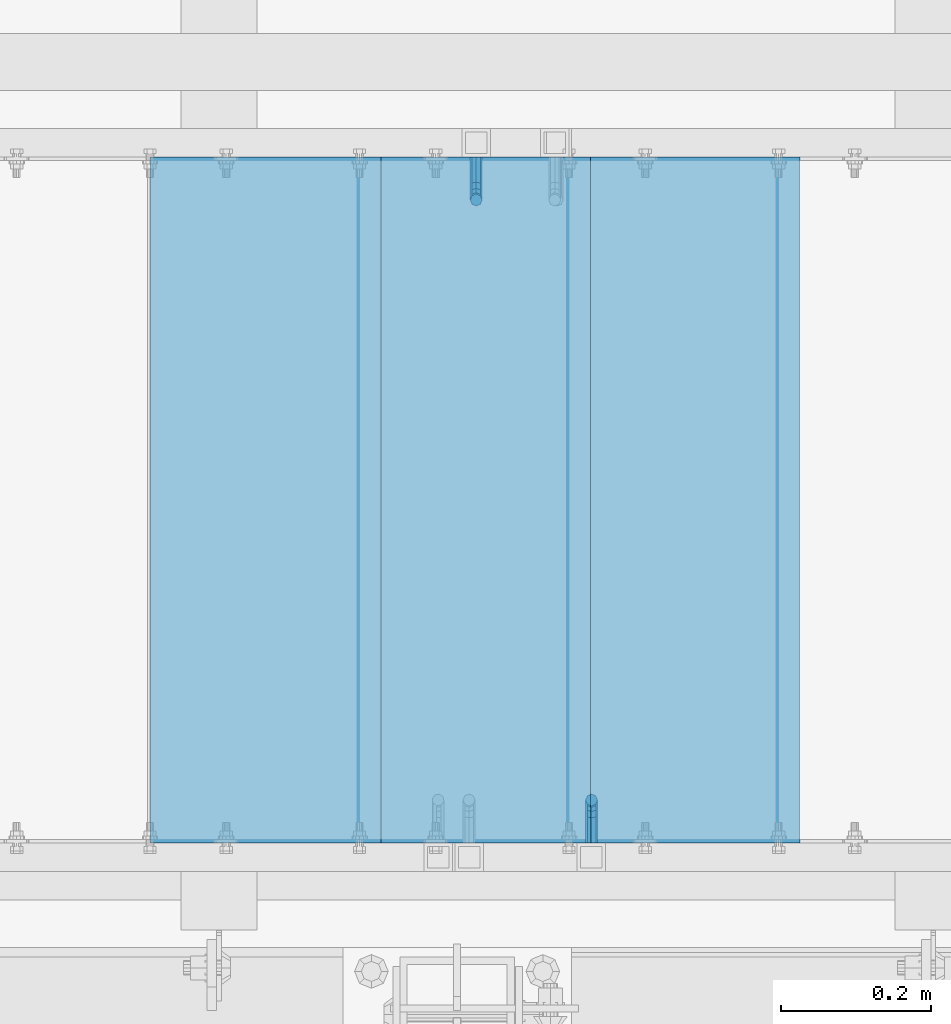
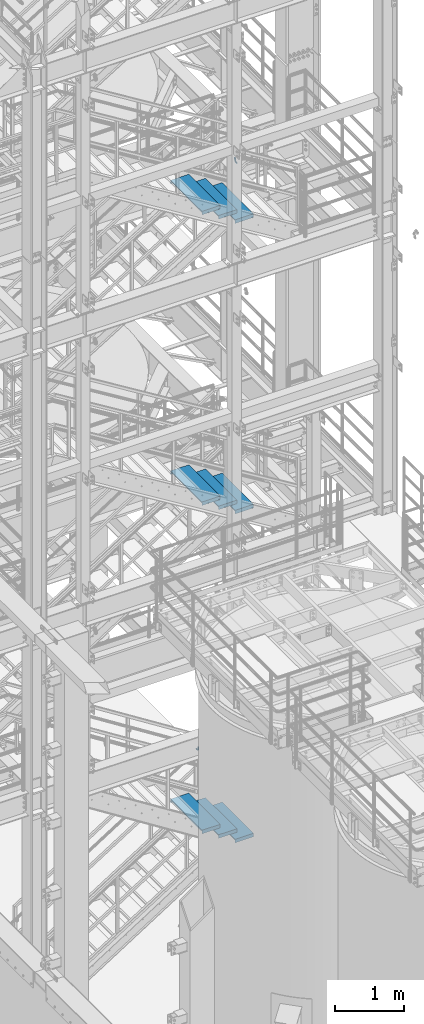
# One storey, part 1149 of 1876: 11 beams, 5 elements without a shape of their own.
"""IFC2X3 building model written with IfcOpenShell, lengths in millimetres."""

from ifc_helpers import new_model, si_unit, frame, origin_with_axes, place, context, subcontext, project, spatial, faceted_brep, material, type_object, element, aggregate, save


model = new_model("IFC2X3")

# Units and contexts
model_context = context("Model", 3, precision=1e-05, world=origin_with_axes())
body_context = subcontext(model_context, "Body", "Model", "MODEL_VIEW")
ifc_project = project(units=[si_unit("LENGTHUNIT", "METRE", prefix="MILLI"), si_unit("AREAUNIT", "SQUARE_METRE"), si_unit("VOLUMEUNIT", "CUBIC_METRE"), si_unit("MASSUNIT", "GRAM", prefix="KILO"), si_unit("TIMEUNIT", "SECOND"), si_unit("PLANEANGLEUNIT", "RADIAN"), si_unit("SOLIDANGLEUNIT", "STERADIAN"), si_unit("THERMODYNAMICTEMPERATUREUNIT", "DEGREE_CELSIUS"), si_unit("LUMINOUSINTENSITYUNIT", "LUMEN")], contexts=[model_context])

# Site, building, storey
site_placement = place(None, origin_with_axes())
site = spatial("IfcSite", under=ifc_project, at=site_placement, CompositionType="ELEMENT")
building_placement = place(site_placement, origin_with_axes())
building = spatial("IfcBuilding", under=site, at=building_placement, Name="Undefined", CompositionType="ELEMENT")
storey_placement = place(building_placement, origin_with_axes())
storey = spatial("IfcBuildingStorey", under=building, at=storey_placement, Name="Undefined", CompositionType="ELEMENT", Elevation=0.0)

# Assembly, beam
assembly_1_placement = place(storey_placement, origin_with_axes())
assembly_1 = element("IfcElementAssembly", 1, at=assembly_1_placement, inside=storey, Name="RAIL", AssemblyPlace="NOTDEFINED", PredefinedType="RIGID_FRAME")
ifc_material = material(Name="STEEL/A36")
beam_type_1 = type_object("IfcBeamType", PredefinedType="NOTDEFINED")
beam_1_placement = place(assembly_1_placement, frame((5259.26600612836, -6883.39999885446, 14836.1019596161), z_axis=(-1.0, 0.0, 0.0), x_axis=(0.0, 1.0, 0.0)))
beam_1 = element("IfcBeam", 2, at=beam_1_placement, type_object=beam_type_1, material=ifc_material, Name="BRACKET", context=body_context, shape_type="Brep", body=[
    faceted_brep([(0.0, -5.61266007566822, 5.61266007566883), (0.0, 0.0, 7.9375), (0.0, 5.61266007566822, 5.61266007566883), (0.0, 7.9375, 0.0), (0.0, 5.61266007566822, -5.61266007566883), (0.0, 0.0, -7.9375), (0.0, -5.61266007566822, -5.61266007566883), (0.0, -7.9375, 0.0), (23.8125, 5.61266007566883, 5.61266007566792), (23.8125, 7.9375, 0.0), (23.8125, 5.61266007566883, -5.61266007566792), (23.8125, 0.0, -7.9375), (23.8125, -5.61266007566883, -5.61266007566792), (23.8125, -7.9375, 0.0), (23.8125, -5.61266007566883, 5.61266007566792), (23.8125, 0.0, 7.9375), (36.5702095103989, -2.53766620105534, 7.9375), (38.7180815328547, 2.64775556579752, 5.61266007566792), (39.6077592547972, 4.79562758825296, 0.0), (38.7180815328547, 2.64775556579752, -5.61266007566792), (36.5702095103989, -2.53766620105534, -7.9375), (34.4223374879439, -7.72308796790867, -5.61266007566792), (33.5326597660014, -9.87095999036364, 0.0), (34.4223374879439, -7.72308796790867, 5.61266007566792), (43.4169233967659, -13.733078129113, 5.61266007566792), (47.385673396765, -9.76432812911298, 7.9375), (41.7730133210971, -15.3769882047809, 0.0), (43.4169233967659, -13.733078129113, -5.61266007566792), (47.385673396765, -9.76432812911298, -7.9375), (51.354423396765, -5.79557812911253, -5.61266007566792), (52.9983334724338, -4.15166805344461, 0.0), (51.354423396765, -5.79557812911253, 5.61266007566792), (54.6123353248231, -20.5797920154787, 7.9375), (59.7977570916764, -18.4319199930233, 5.61266007566792), (49.4269135579698, -22.7276640379341, 5.61266007566792), (47.2790415355148, -23.6173417598766, 0.0), (49.4269135579698, -22.7276640379341, -5.61266007566792), (54.6123353248231, -20.5797920154787, -7.9375), (59.7977570916764, -18.4319199930233, -5.61266007566792), (61.9456291141314, -17.5422422710808, 0.0), (62.7626616015468, -33.3375015258789, 5.61266007566792), (65.0875015258789, -33.3375015258789, 0.0), (57.1500015258789, -33.3375015258789, 7.9375), (51.5373414502101, -33.3375015258789, 5.61266007566792), (49.2125015258789, -33.3375015258789, 0.0), (51.5373414502101, -33.3375015258789, -5.61266007566792), (57.1500015258789, -33.3375015258789, -7.9375), (62.7626616015468, -33.3375015258789, -5.61266007566792), (65.0875015258789, -66.4903966648035, 0.0), (62.7626616015468, -63.0131930011103, -5.61266007566792), (57.1500015258789, -61.5728880844745, -7.9375), (51.537341450211, -63.0131930011103, -5.61266007566792), (49.2125015258789, -66.4903966648035, 0.0), (51.537341450211, -69.9676003284985, 5.61266007566792), (57.1500015258789, -71.4079052451343, 7.9375), (62.7626616015468, -69.9676003284985, 5.61266007566792)], [[[0, 1, 2, 3, 4, 5, 6, 7]], [[3, 2, 8, 9]], [[4, 3, 9, 10]], [[5, 4, 10, 11]], [[6, 5, 11, 12]], [[7, 6, 12, 13]], [[0, 7, 13, 14]], [[1, 0, 14, 15]], [[2, 1, 15, 8]], [[8, 15, 16, 17]], [[9, 8, 17, 18]], [[10, 9, 18, 19]], [[11, 10, 19, 20]], [[12, 11, 20, 21]], [[13, 12, 21, 22]], [[14, 13, 22, 23]], [[15, 14, 23, 16]], [[23, 24, 25, 16]], [[22, 26, 24, 23]], [[21, 27, 26, 22]], [[20, 28, 27, 21]], [[19, 29, 28, 20]], [[18, 30, 29, 19]], [[17, 31, 30, 18]], [[16, 25, 31, 17]], [[25, 32, 33, 31]], [[24, 34, 32, 25]], [[26, 35, 34, 24]], [[27, 36, 35, 26]], [[28, 37, 36, 27]], [[29, 38, 37, 28]], [[30, 39, 38, 29]], [[31, 33, 39, 30]], [[33, 40, 41, 39]], [[32, 42, 40, 33]], [[34, 43, 42, 32]], [[35, 44, 43, 34]], [[36, 45, 44, 35]], [[37, 46, 45, 36]], [[38, 47, 46, 37]], [[39, 41, 47, 38]], [[47, 41, 48, 49]], [[46, 47, 49, 50]], [[45, 46, 50, 51]], [[44, 45, 51, 52]], [[43, 44, 52, 53]], [[42, 43, 53, 54]], [[40, 42, 54, 55]], [[41, 40, 55, 48]], [[54, 53, 52, 51, 50, 49, 48, 55]]]),
])
aggregate(assembly_1, [beam_1])

assembly_2_placement = place(storey_placement, origin_with_axes())
assembly_2 = element("IfcElementAssembly", 3, at=assembly_2_placement, inside=storey, Name="RAIL", AssemblyPlace="NOTDEFINED", PredefinedType="RIGID_FRAME")
beam_2_placement = place(assembly_2_placement, frame((5105.40000153775, -5969.00000106773, 3934.46117682293), z_axis=(-1.0, 0.0, 0.0), x_axis=(0.0, -1.0, 0.0)))
beam_2 = element("IfcBeam", 4, at=beam_2_placement, type_object=beam_type_1, material=ifc_material, Name="BRACKET", context=body_context, shape_type="Brep", body=[
    faceted_brep([(0.0, -5.61266007566822, 5.61266007566883), (0.0, 0.0, 7.9375), (0.0, 5.61266007566822, 5.61266007566883), (0.0, 7.9375, 0.0), (0.0, 5.61266007566822, -5.61266007566883), (0.0, 0.0, -7.9375), (0.0, -5.61266007566822, -5.61266007566883), (0.0, -7.9375, 0.0), (23.8125, -5.61266007566883, -5.61266007566792), (23.8125, -7.9375, 0.0), (23.8125, -5.61266007566883, 5.61266007566792), (23.8125, 0.0, 7.9375), (23.8125, 5.61266007566883, 5.61266007566792), (23.8125, 7.9375, 0.0), (23.8125, 5.61266007566883, -5.61266007566792), (23.8125, 0.0, -7.9375), (36.5702095103998, 2.53766620105671, -7.9375), (38.7180815328556, -2.64775556579843, -5.61266007566792), (39.6077592547981, -4.79562758825341, 0.0), (38.7180815328556, -2.64775556579843, 5.61266007566792), (36.5702095103998, 2.53766620105671, 7.9375), (34.4223374879448, 7.72308796790821, 5.61266007566792), (33.5326597660023, 9.87095999036319, 0.0), (34.4223374879448, 7.72308796790821, -5.61266007566792), (43.4169233967659, 13.733078129113, -5.61266007566792), (47.3856733967659, 9.76432812911298, -7.9375), (41.773013321098, 15.3769882047818, 0.0), (43.4169233967659, 13.733078129113, 5.61266007566792), (47.3856733967659, 9.76432812911298, 7.9375), (51.3544233967659, 5.79557812911298, 5.61266007566792), (52.9983334724348, 4.15166805344415, 0.0), (51.3544233967659, 5.79557812911298, -5.61266007566792), (54.6123353248231, 20.5797920154801, -7.9375), (59.7977570916764, 18.4319199930251, -5.61266007566792), (49.4269135579698, 22.727664037935, -5.61266007566792), (47.2790415355148, 23.6173417598766, 0.0), (49.4269135579698, 22.727664037935, 5.61266007566792), (54.6123353248231, 20.5797920154801, 7.9375), (59.7977570916764, 18.4319199930251, 5.61266007566792), (61.9456291141314, 17.5422422710835, 0.0), (62.7626616015468, 33.3375015258789, -5.61266007566792), (65.0875015258789, 33.3375015258789, 0.0), (57.1500015258789, 33.3375015258789, -7.9375), (51.5373414502101, 33.3375015258789, -5.61266007566792), (49.2125015258789, 33.3375015258789, 0.0), (51.5373414502101, 33.3375015258789, 5.61266007566792), (57.1500015258789, 33.3375015258789, 7.9375), (62.7626616015468, 33.3375015258789, 5.61266007566792), (65.0875015258789, 67.3558732176816, 0.0), (62.7626616015468, 70.9165696288755, 5.61266007566837), (57.1500015258789, 72.3914583738861, 7.9375), (51.537341450211, 70.9165696288755, 5.61266007566837), (49.2125015258789, 67.3558732176816, 0.0), (51.537341450211, 63.7951768064877, -5.61266007566837), (57.1500015258789, 62.3202880614781, -7.9375), (62.7626616015468, 63.7951768064877, -5.61266007566837)], [[[0, 1, 2, 3, 4, 5, 6, 7]], [[7, 6, 8, 9]], [[0, 7, 9, 10]], [[1, 0, 10, 11]], [[2, 1, 11, 12]], [[3, 2, 12, 13]], [[4, 3, 13, 14]], [[5, 4, 14, 15]], [[6, 5, 15, 8]], [[8, 15, 16, 17]], [[9, 8, 17, 18]], [[10, 9, 18, 19]], [[11, 10, 19, 20]], [[12, 11, 20, 21]], [[13, 12, 21, 22]], [[14, 13, 22, 23]], [[15, 14, 23, 16]], [[23, 24, 25, 16]], [[22, 26, 24, 23]], [[21, 27, 26, 22]], [[20, 28, 27, 21]], [[19, 29, 28, 20]], [[18, 30, 29, 19]], [[17, 31, 30, 18]], [[16, 25, 31, 17]], [[25, 32, 33, 31]], [[24, 34, 32, 25]], [[26, 35, 34, 24]], [[27, 36, 35, 26]], [[28, 37, 36, 27]], [[29, 38, 37, 28]], [[30, 39, 38, 29]], [[31, 33, 39, 30]], [[33, 40, 41, 39]], [[32, 42, 40, 33]], [[34, 43, 42, 32]], [[35, 44, 43, 34]], [[36, 45, 44, 35]], [[37, 46, 45, 36]], [[38, 47, 46, 37]], [[39, 41, 47, 38]], [[47, 41, 48, 49]], [[46, 47, 49, 50]], [[45, 46, 50, 51]], [[44, 45, 51, 52]], [[43, 44, 52, 53]], [[42, 43, 53, 54]], [[40, 42, 54, 55]], [[41, 40, 55, 48]], [[54, 53, 52, 51, 50, 49, 48, 55]]]),
])
aggregate(assembly_2, [beam_2])

# Assembly, beams
assembly_3_placement = place(storey_placement, origin_with_axes())
assembly_3 = element("IfcElementAssembly", 5, at=assembly_3_placement, inside=storey, Name="STRINGER", AssemblyPlace="NOTDEFINED", PredefinedType="RIGID_FRAME")
beam_type_2 = type_object("IfcBeamType", PredefinedType="NOTDEFINED")
beam_3_placement = place(assembly_3_placement, frame((4824.41250077649, -5973.76300114651, 14175.0814814819), z_axis=(1.0, 0.0, 0.0), x_axis=(0.0, -1.0, 0.0)))
beam_3 = element("IfcBeam", 6, at=beam_3_placement, type_object=beam_type_2, material=ifc_material, Name="TREAD", context=body_context, shape_type="Brep", body=[
    faceted_brep([(-7.45785655453801e-11, 53.9750000000167, -153.9875), (-7.45785655453801e-11, 53.9750000000167, 153.987506103515), (0.0, 9.52499999999964, 153.9875), (-7.45785655453801e-11, 9.52499999999964, -153.9875), (-4.76300000007541, 53.9750000000167, -153.9875), (-4.76300000007541, 53.9750000000167, 153.987506103515), (-4.76300000007541, -9.52499999998327, -153.9875), (-4.76300000007541, -9.52500000019427, 153.987536621094), (909.637000008669, -9.52500000248983, 153.987506103515), (909.637000008669, 53.9749999975102, 153.987506103515), (904.87400000867, 53.9749999975102, 153.987506103515), (904.87400000867, 9.52499999999964, 153.987506103515), (-7.45785655453801e-11, -9.52500000019427, 153.987536621094), (904.87400000867, -9.52500000248983, 153.987506103515), (904.87400000867, 9.52499999999964, -153.9875), (909.637000008669, -9.52500000248983, -153.9875), (909.637000008669, 53.9749999975102, -153.9875), (904.87400000867, 53.9749999975102, -153.9875)], [[[0, 1, 2, 3]], [[1, 0, 4, 5]], [[5, 4, 6, 7]], [[8, 9, 10, 11, 2, 1, 5, 7, 12, 13]], [[14, 3, 2, 11]], [[15, 8, 13, 12, 7, 6]], [[9, 16, 17, 10]], [[16, 9, 8, 15]], [[16, 15, 6, 4, 0, 3, 14, 17]], [[10, 17, 14, 11]]]),
])
beam_4_placement = place(assembly_3_placement, frame((5103.81250069809, -5973.76300114632, 14001.9851851856), z_axis=(1.0, 0.0, 0.0), x_axis=(0.0, -1.0, 0.0)))
beam_4 = element("IfcBeam", 7, at=beam_4_placement, type_object=beam_type_2, material=ifc_material, Name="TREAD", context=body_context, shape_type="Brep", body=[
    faceted_brep([(-7.45785655453801e-11, 53.9750000000167, -153.9875), (-7.45785655453801e-11, 53.9750000000167, 153.987506103515), (0.0, 9.52499999999964, 153.9875), (-7.45785655453801e-11, 9.52499999999964, -153.9875), (-4.76300000007541, 53.9750000000167, -153.9875), (-4.76300000007541, 53.9750000000167, 153.987506103515), (-4.76300000007541, -9.52499999998327, -153.9875), (-4.76300000007541, -9.52500000019427, 153.987536621094), (909.637000008669, 53.9749999975102, 153.987506103515), (904.87400000867, 53.9749999975102, 153.987506103515), (904.87400000867, 9.52499999999964, 153.987506103515), (909.637000008669, -9.52500000248983, 153.987506103515), (904.87400000867, 9.52499999999964, -153.9875), (909.637000008669, -9.52500000248983, -153.9875), (909.637000008669, 53.9749999975102, -153.9875), (904.87400000867, 53.9749999975102, -153.9875)], [[[0, 1, 2, 3]], [[1, 0, 4, 5]], [[5, 4, 6, 7]], [[8, 9, 10, 2, 1, 5, 7, 11]], [[12, 3, 2, 10]], [[13, 11, 7, 6]], [[8, 14, 15, 9]], [[14, 8, 11, 13]], [[14, 13, 6, 4, 0, 3, 12, 15]], [[9, 15, 12, 10]]]),
])
beam_5_placement = place(assembly_3_placement, frame((5383.21250061969, -5973.76300114619, 13828.8888888893), z_axis=(1.0, 0.0, 0.0), x_axis=(0.0, -1.0, 0.0)))
beam_5 = element("IfcBeam", 8, at=beam_5_placement, type_object=beam_type_2, material=ifc_material, Name="TREAD", context=body_context, shape_type="Brep", body=[
    faceted_brep([(-7.45785655453801e-11, 53.9750000000167, -153.9875), (-7.45785655453801e-11, 53.9750000000167, 153.987506103515), (0.0, 9.52499999999964, 153.9875), (-7.45785655453801e-11, 9.52499999999964, -153.9875), (-4.76300000007541, 53.9750000000167, -153.9875), (-4.76300000007541, 53.9750000000167, 153.987506103515), (-4.76300000007541, -9.52499999998327, -153.9875), (-4.76300000007541, -9.52500000019427, 153.987536621094), (909.637000008669, -9.52500000248983, 153.987506103515), (909.637000008669, 53.9749999975102, 153.987506103515), (904.87400000867, 53.9749999975102, 153.987506103515), (904.87400000867, 9.52499999999964, 153.987506103515), (-7.45785655453801e-11, -9.52500000019427, 153.987536621094), (904.87400000867, -9.52500000248983, 153.987506103515), (904.87400000867, 9.52499999999964, -153.9875), (909.637000008669, -9.52500000248983, -153.9875), (909.637000008669, 53.9749999975102, -153.9875), (904.87400000867, 53.9749999975102, -153.9875)], [[[0, 1, 2, 3]], [[1, 0, 4, 5]], [[5, 4, 6, 7]], [[8, 9, 10, 11, 2, 1, 5, 7, 12, 13]], [[14, 3, 2, 11]], [[15, 8, 13, 12, 7, 6]], [[9, 16, 17, 10]], [[16, 9, 8, 15]], [[16, 15, 6, 4, 0, 3, 14, 17]], [[10, 17, 14, 11]]]),
])
aggregate(assembly_3, [beam_3, beam_4, beam_5])

assembly_4_placement = place(storey_placement, origin_with_axes())
assembly_4 = element("IfcElementAssembly", 9, at=assembly_4_placement, inside=storey, Name="STRINGER", AssemblyPlace="NOTDEFINED", PredefinedType="RIGID_FRAME")
beam_6_placement = place(assembly_4_placement, frame((4824.41250059405, -5973.76300114622, 9012.76666698753), z_axis=(1.0, 0.0, 0.0), x_axis=(0.0, -1.0, 0.0)))
beam_6 = element("IfcBeam", 10, at=beam_6_placement, type_object=beam_type_2, material=ifc_material, Name="TREAD", context=body_context, shape_type="Brep", body=[
    faceted_brep([(-7.45785655453801e-11, 53.9750000000167, -153.9875), (-7.45785655453801e-11, 53.9750000000167, 153.987506103515), (0.0, 9.52499999999964, 153.9875), (-7.45785655453801e-11, 9.52499999999964, -153.9875), (-4.76300000007541, 53.9750000000167, -153.9875), (-4.76300000007541, 53.9750000000167, 153.987506103515), (-4.76300000007541, -9.52499999998327, -153.9875), (-4.76300000007541, -9.52500000019427, 153.987536621094), (909.637000008669, -9.52500000248983, 153.987506103515), (909.637000008669, 53.9749999975102, 153.987506103515), (904.87400000867, 53.9749999975102, 153.987506103515), (904.87400000867, 9.52499999999964, 153.987506103515), (-7.45785655453801e-11, -9.52500000019427, 153.987536621094), (904.87400000867, -9.52500000248983, 153.987506103515), (904.87400000867, 9.52499999999964, -153.9875), (909.637000008669, -9.52500000248983, -153.9875), (909.637000008669, 53.9749999975102, -153.9875), (904.87400000867, 53.9749999975102, -153.9875)], [[[0, 1, 2, 3]], [[1, 0, 4, 5]], [[5, 4, 6, 7]], [[8, 9, 10, 11, 2, 1, 5, 7, 12, 13]], [[14, 3, 2, 11]], [[15, 8, 13, 12, 7, 6]], [[9, 16, 17, 10]], [[16, 9, 8, 15]], [[16, 15, 6, 4, 0, 3, 14, 17]], [[10, 17, 14, 11]]]),
])
beam_7_placement = place(assembly_4_placement, frame((5103.81250052451, -5973.76300114647, 8840.89333359034), z_axis=(1.0, 0.0, 0.0), x_axis=(0.0, -1.0, 0.0)))
beam_7 = element("IfcBeam", 11, at=beam_7_placement, type_object=beam_type_2, material=ifc_material, Name="TREAD", context=body_context, shape_type="Brep", body=[
    faceted_brep([(-7.45785655453801e-11, 53.9750000000167, -153.9875), (-7.45785655453801e-11, 53.9750000000167, 153.987506103515), (0.0, 9.52499999999964, 153.9875), (-7.45785655453801e-11, 9.52499999999964, -153.9875), (-4.76300000007541, 53.9750000000167, -153.9875), (-4.76300000007541, 53.9750000000167, 153.987506103515), (-4.76300000007541, -9.52499999998327, -153.9875), (-4.76300000007541, -9.52500000019427, 153.987536621094), (909.637000008669, -9.52500000248983, 153.987506103515), (909.637000008669, 53.9749999975102, 153.987506103515), (904.87400000867, 53.9749999975102, 153.987506103515), (904.87400000867, 9.52499999999964, 153.987506103515), (-7.45785655453801e-11, -9.52500000019427, 153.987536621094), (904.87400000867, -9.52500000248983, 153.987506103515), (904.87400000867, 9.52499999999964, -153.9875), (909.637000008669, -9.52500000248983, -153.9875), (909.637000008669, 53.9749999975102, -153.9875), (904.87400000867, 53.9749999975102, -153.9875)], [[[0, 1, 2, 3]], [[1, 0, 4, 5]], [[5, 4, 6, 7]], [[8, 9, 10, 11, 2, 1, 5, 7, 12, 13]], [[14, 3, 2, 11]], [[15, 8, 13, 12, 7, 6]], [[9, 16, 17, 10]], [[16, 9, 8, 15]], [[16, 15, 6, 4, 0, 3, 14, 17]], [[10, 17, 14, 11]]]),
])
beam_8_placement = place(assembly_4_placement, frame((5383.21250045497, -5973.76300114673, 8669.02000019316), z_axis=(1.0, 0.0, 0.0), x_axis=(0.0, -1.0, 0.0)))
beam_8 = element("IfcBeam", 12, at=beam_8_placement, type_object=beam_type_2, material=ifc_material, Name="TREAD", context=body_context, shape_type="Brep", body=[
    faceted_brep([(-7.45785655453801e-11, 53.9750000000167, -153.9875), (-7.45785655453801e-11, 53.9750000000167, 153.987506103515), (0.0, 9.52499999999964, 153.9875), (-7.45785655453801e-11, 9.52499999999964, -153.9875), (-4.76300000007541, 53.9750000000167, -153.9875), (-4.76300000007541, 53.9750000000167, 153.987506103515), (-4.76300000007541, -9.52499999998327, -153.9875), (-4.76300000007541, -9.52500000019427, 153.987536621094), (909.637000008669, -9.52500000248983, 153.987506103515), (909.637000008669, 53.9749999975102, 153.987506103515), (904.87400000867, 53.9749999975102, 153.987506103515), (904.87400000867, 9.52499999999964, 153.987506103515), (-7.45785655453801e-11, -9.52500000019427, 153.987536621094), (904.87400000867, -9.52500000248983, 153.987506103515), (904.87400000867, 9.52499999999964, -153.9875), (909.637000008669, -9.52500000248983, -153.9875), (909.637000008669, 53.9749999975102, -153.9875), (904.87400000867, 53.9749999975102, -153.9875)], [[[0, 1, 2, 3]], [[1, 0, 4, 5]], [[5, 4, 6, 7]], [[8, 9, 10, 11, 2, 1, 5, 7, 12, 13]], [[14, 3, 2, 11]], [[15, 8, 13, 12, 7, 6]], [[9, 16, 17, 10]], [[16, 9, 8, 15]], [[16, 15, 6, 4, 0, 3, 14, 17]], [[10, 17, 14, 11]]]),
])
aggregate(assembly_4, [beam_6, beam_7, beam_8])

assembly_5_placement = place(storey_placement, origin_with_axes())
assembly_5 = element("IfcElementAssembly", 13, at=assembly_5_placement, inside=storey, Name="STRINGER", AssemblyPlace="NOTDEFINED", PredefinedType="RIGID_FRAME")
beam_9_placement = place(assembly_5_placement, frame((4824.41250261152, -5973.76300113261, 3181.02155172864), z_axis=(1.0, 0.0, 0.0), x_axis=(0.0, -1.0, 0.0)))
beam_9 = element("IfcBeam", 14, at=beam_9_placement, type_object=beam_type_2, material=ifc_material, Name="TREAD", context=body_context, shape_type="Brep", body=[
    faceted_brep([(-7.45785655453801e-11, 53.9750000000167, -153.9875), (-7.45785655453801e-11, 53.9750000000167, 153.987506103515), (0.0, 9.52499999999964, 153.9875), (-7.45785655453801e-11, 9.52499999999964, -153.9875), (-4.76300000007541, 53.9750000000167, -153.9875), (-4.76300000007541, 53.9750000000167, 153.987506103515), (-4.76300000007541, -9.52499999998327, -153.9875), (-4.76300000007541, -9.52500000019427, 153.987536621094), (909.637000008669, -9.52500000248983, 153.987506103515), (909.637000008669, 53.9749999975102, 153.987506103515), (904.87400000867, 53.9749999975102, 153.987506103515), (904.87400000867, 9.52499999999964, 153.987506103515), (-7.45785655453801e-11, -9.52500000019427, 153.987536621094), (904.87400000867, -9.52500000248983, 153.987506103515), (904.87400000867, 9.52499999999964, -153.9875), (909.637000008669, -9.52500000248983, -153.9875), (909.637000008669, 53.9749999975102, -153.9875), (904.87400000867, 53.9749999975102, -153.9875)], [[[0, 1, 2, 3]], [[1, 0, 4, 5]], [[5, 4, 6, 7]], [[8, 9, 10, 11, 2, 1, 5, 7, 12, 13]], [[14, 3, 2, 11]], [[15, 8, 13, 12, 7, 6]], [[9, 16, 17, 10]], [[16, 9, 8, 15]], [[16, 15, 6, 4, 0, 3, 14, 17]], [[10, 17, 14, 11]]]),
])
beam_10_placement = place(assembly_5_placement, frame((5103.81250229372, -5973.76300113245, 3003.768965522), z_axis=(1.0, 0.0, 0.0), x_axis=(0.0, -1.0, 0.0)))
beam_10 = element("IfcBeam", 15, at=beam_10_placement, type_object=beam_type_2, material=ifc_material, Name="TREAD", context=body_context, shape_type="Brep", body=[
    faceted_brep([(-7.45785655453801e-11, 53.9750000000167, -153.9875), (-7.45785655453801e-11, 53.9750000000167, 153.987506103515), (0.0, 9.52499999999964, 153.9875), (-7.45785655453801e-11, 9.52499999999964, -153.9875), (-4.76300000007541, 53.9750000000167, -153.9875), (-4.76300000007541, 53.9750000000167, 153.987506103515), (-4.76300000007541, -9.52499999998327, -153.9875), (-4.76300000007541, -9.52500000019427, 153.987536621094), (909.637000008669, -9.52500000248983, 153.987506103515), (909.637000008669, 53.9749999975102, 153.987506103515), (904.87400000867, 53.9749999975102, 153.987506103515), (904.87400000867, 9.52499999999964, 153.987506103515), (-7.45785655453801e-11, -9.52500000019427, 153.987536621094), (904.87400000867, -9.52500000248983, 153.987506103515), (904.87400000867, 9.52499999999964, -153.9875), (909.637000008669, -9.52500000248983, -153.9875), (909.637000008669, 53.9749999975102, -153.9875), (904.87400000867, 53.9749999975102, -153.9875)], [[[0, 1, 2, 3]], [[1, 0, 4, 5]], [[5, 4, 6, 7]], [[8, 9, 10, 11, 2, 1, 5, 7, 12, 13]], [[14, 3, 2, 11]], [[15, 8, 13, 12, 7, 6]], [[9, 16, 17, 10]], [[16, 9, 8, 15]], [[16, 15, 6, 4, 0, 3, 14, 17]], [[10, 17, 14, 11]]]),
])
beam_11_placement = place(assembly_5_placement, frame((5383.21250197591, -5973.76300113229, 2826.51637931536), z_axis=(1.0, 0.0, 0.0), x_axis=(0.0, -1.0, 0.0)))
beam_11 = element("IfcBeam", 16, at=beam_11_placement, type_object=beam_type_2, material=ifc_material, Name="TREAD", context=body_context, shape_type="Brep", body=[
    faceted_brep([(-7.45785655453801e-11, 53.9750000000167, -153.9875), (-7.45785655453801e-11, 53.9750000000167, 153.987506103515), (0.0, 9.52499999999964, 153.9875), (-7.45785655453801e-11, 9.52499999999964, -153.9875), (-4.76300000007541, 53.9750000000167, -153.9875), (-4.76300000007541, 53.9750000000167, 153.987506103515), (-4.76300000007541, -9.52499999998327, -153.9875), (-4.76300000007541, -9.52500000019427, 153.987536621094), (909.637000008669, -9.52500000248983, 153.987506103515), (909.637000008669, 53.9749999975102, 153.987506103515), (904.87400000867, 53.9749999975102, 153.987506103515), (904.87400000867, 9.52499999999964, 153.987506103515), (-7.45785655453801e-11, -9.52500000019427, 153.987536621094), (904.87400000867, -9.52500000248983, 153.987506103515), (904.87400000867, 9.52499999999964, -153.9875), (909.637000008669, -9.52500000248983, -153.9875), (909.637000008669, 53.9749999975102, -153.9875), (904.87400000867, 53.9749999975102, -153.9875)], [[[0, 1, 2, 3]], [[1, 0, 4, 5]], [[5, 4, 6, 7]], [[8, 9, 10, 11, 2, 1, 5, 7, 12, 13]], [[14, 3, 2, 11]], [[15, 8, 13, 12, 7, 6]], [[9, 16, 17, 10]], [[16, 9, 8, 15]], [[16, 15, 6, 4, 0, 3, 14, 17]], [[10, 17, 14, 11]]]),
])
aggregate(assembly_5, [beam_9, beam_10, beam_11])

save(model, "model.ifc")
